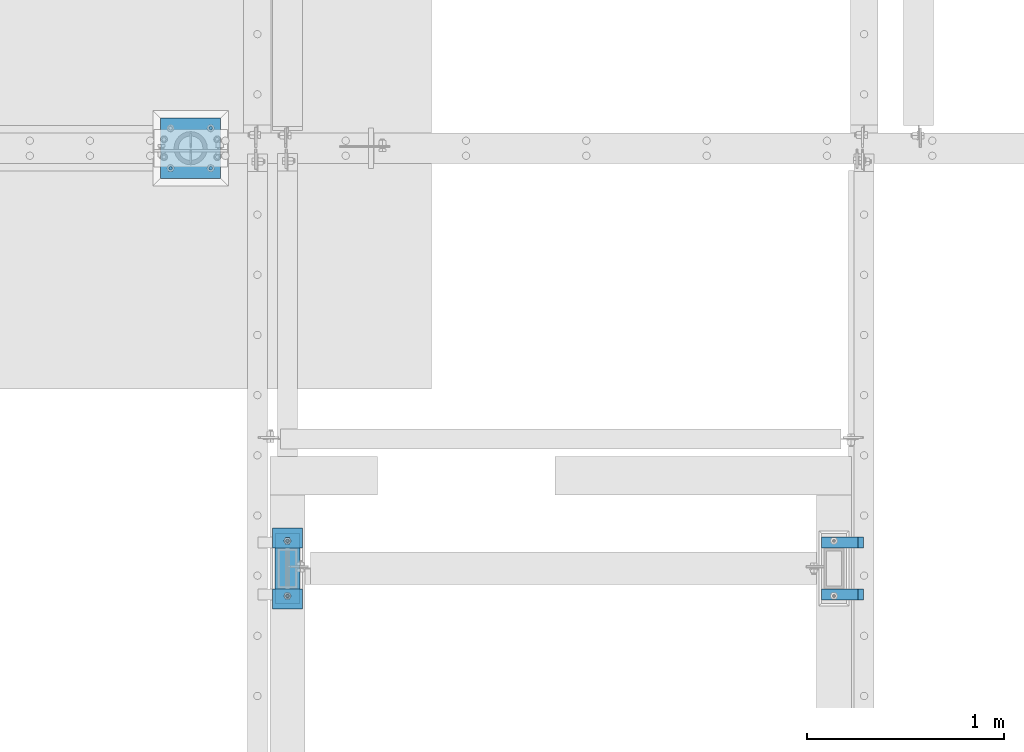
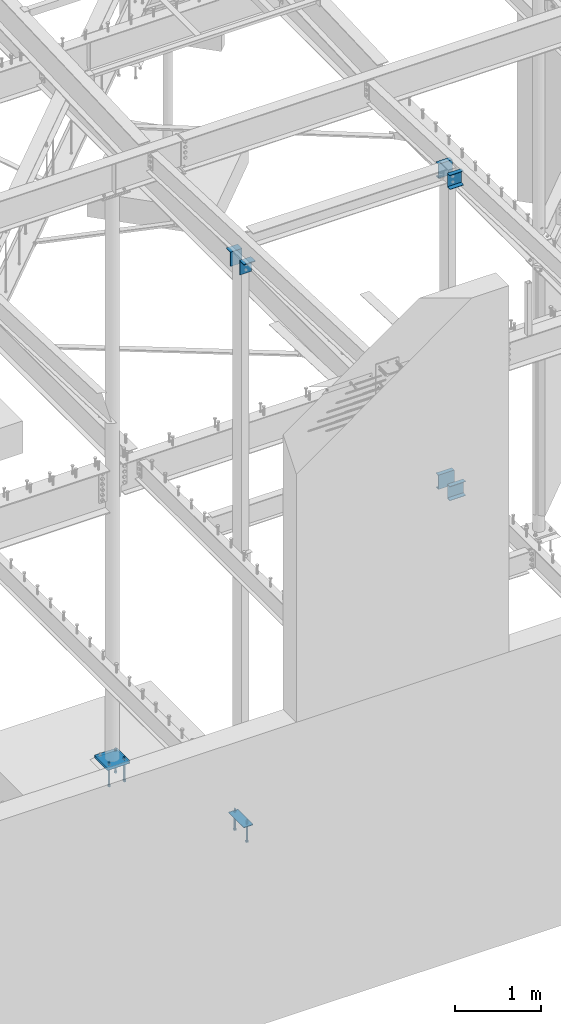
# One storey, part 411 of 975: 15 beams.
"""IFC2X3 building model written with IfcOpenShell, lengths in millimetres."""

import ifcopenshell
import ifcopenshell.guid

model = None  # the IFC model being written
_history = None  # IfcOwnerHistory: only IFC2X3 demands one
_inside = {}  # id of a spatial element -> (the spatial element, [elements in it])
_under = {}  # id of a project, library or spatial element -> (it, [spatial elements below it])
_declared = {}  # id of a project -> (the project, [libraries it declares])
_typed = {}  # id of a type object -> (the type object, [elements of that type])
_made_of = {}  # id of a material, layer set ... -> (it, [elements and type objects made of it])


def new_model(schema):
    """Start an empty IFC model of exactly this schema.

    Asked for "IFC4X3", IfcOpenShell would pick the latest addendum, in which some entities
    have other attributes; the version numbers below select the first issue.
    IFC2X3 requires an IfcOwnerHistory on every rooted entity: one is made here for all.
    """
    global model, _history
    if schema == "IFC4X3":
        model = ifcopenshell.file(schema_version=(4, 3, 0, 0))
    else:
        model = ifcopenshell.file(schema=schema)
    _inside.clear()
    _under.clear()
    _declared.clear()
    _typed.clear()
    _made_of.clear()
    _history = None
    if model.schema == "IFC2X3":
        org = make("IfcOrganization", Name="unknown")
        user = make(
            "IfcPersonAndOrganization",
            ThePerson=make("IfcPerson", FamilyName="unknown"),
            TheOrganization=org,
        )
        app = make(
            "IfcApplication",
            ApplicationDeveloper=org,
            Version="unknown",
            ApplicationFullName="unknown",
            ApplicationIdentifier="unknown",
        )
        _history = make(
            "IfcOwnerHistory",
            OwningUser=user,
            OwningApplication=app,
            ChangeAction="ADDED",
            CreationDate=0,
        )
    return model


def make(cls, **values):
    """One entity of the class cls with the attributes given. An attribute that is None is left unset."""
    return model.create_entity(
        cls, **{name: value for name, value in values.items() if value is not None}
    )


def rooted(cls, **values):
    """An entity with a GlobalId (a new one), such as an element, a storey or a relation."""
    return make(cls, GlobalId=ifcopenshell.guid.new(), OwnerHistory=_history, **values)


def si_unit(unit_type, name, prefix=None):
    """IfcSIUnit, for example si_unit("LENGTHUNIT", "METRE", prefix="MILLI")."""
    return make("IfcSIUnit", UnitType=unit_type, Prefix=prefix, Name=name)


def assignment(units):
    """IfcUnitAssignment: the units of a project."""
    return None if units is None else make("IfcUnitAssignment", Units=units)


def point(xyz):
    """IfcCartesianPoint."""
    return None if xyz is None else make("IfcCartesianPoint", Coordinates=xyz)


def direction(xyz):
    """IfcDirection."""
    return None if xyz is None else make("IfcDirection", DirectionRatios=xyz)


def frame(location, z_axis=None, x_axis=None):
    """IfcAxis2Placement3D, a coordinate frame: its origin and axes. An axis left out is left unset."""
    return make(
        "IfcAxis2Placement3D",
        Location=point(location),
        Axis=direction(z_axis),
        RefDirection=direction(x_axis),
    )


def origin_with_axes():
    """The frame at (0, 0, 0) with the z axis (0, 0, 1) and the x axis (1, 0, 0) written out."""
    return frame((0.0, 0.0, 0.0), z_axis=(0.0, 0.0, 1.0), x_axis=(1.0, 0.0, 0.0))


def place(relative_to, where):
    """IfcLocalPlacement: puts the frame where relative to a parent placement (None: the world)."""
    return make(
        "IfcLocalPlacement", PlacementRelTo=relative_to, RelativePlacement=where
    )


def context(
    kind, dimensions, precision=None, world=None, true_north=None, identifier=None
):
    """IfcGeometricRepresentationContext, for example the 3D "Model" context."""
    return make(
        "IfcGeometricRepresentationContext",
        ContextIdentifier=identifier,
        ContextType=kind,
        CoordinateSpaceDimension=dimensions,
        Precision=precision,
        WorldCoordinateSystem=world,
        TrueNorth=true_north,
    )


def subcontext(parent, identifier, kind, view, scale=None):
    """IfcGeometricRepresentationSubContext, for example "Body" below "Model"."""
    return make(
        "IfcGeometricRepresentationSubContext",
        ContextIdentifier=identifier,
        ContextType=kind,
        ParentContext=parent,
        TargetScale=scale,
        TargetView=view,
    )


def project(units=None, contexts=None):
    """IfcProject with its units and contexts."""
    return rooted(
        "IfcProject",
        Name="project",
        RepresentationContexts=contexts,
        UnitsInContext=assignment(units),
    )


def spatial(cls, under=None, at=None, **own):
    """A site, building, storey or space (cls), placed at a placement, below another one or the project."""
    s = rooted(cls, ObjectPlacement=at, **own)
    if under is not None:
        _under.setdefault(under.id(), (under, []))[1].append(s)
    return s


def faces_of(points, faces, orient=None, outer=None):
    """IfcFace entities. A face is a list of loops; a loop is a list of indices into points, from 0.

    orient and outer hold one flag for each loop. By default every Orientation is true, the
    first loop of a face is its IfcFaceOuterBound and the others are IfcFaceBound.
    """
    made = []
    for i, loops in enumerate(faces):
        bounds = []
        for j, loop in enumerate(loops):
            is_outer = j == 0 if outer is None else outer[i][j]
            bounds.append(
                make(
                    "IfcFaceOuterBound" if is_outer else "IfcFaceBound",
                    Bound=make("IfcPolyLoop", Polygon=[points[k] for k in loop]),
                    Orientation=True if orient is None else orient[i][j],
                )
            )
        made.append(make("IfcFace", Bounds=bounds))
    return made


def faceted_brep(points, faces, orient=None, outer=None, voids=None):
    """IfcFacetedBrep: a solid bounded by flat faces; with voids (closed shells), ...WithVoids."""
    shared = [point(p) for p in points]
    hull = make("IfcClosedShell", CfsFaces=faces_of(shared, faces, orient, outer))
    if voids is None:
        return make("IfcFacetedBrep", Outer=hull)
    return make(
        "IfcFacetedBrepWithVoids",
        Outer=hull,
        Voids=[
            make(cls, CfsFaces=faces_of(shared, fs, o, b)) for cls, fs, o, b in voids
        ],
    )


def shape(context_of_items, identifier, shape_type, items):
    """IfcShapeRepresentation: the items that make up one representation, for example the "Body"."""
    return make(
        "IfcShapeRepresentation",
        ContextOfItems=context_of_items,
        RepresentationIdentifier=identifier,
        RepresentationType=shape_type,
        Items=items,
    )


def material(Name=None, Category=None):
    """IfcMaterial."""
    return make("IfcMaterial", Name=Name, Category=Category)


def made_of(thing, what):
    """Note that an element or type object is made of a material, layer set ...; save() writes the relation."""
    if what is not None:
        _made_of.setdefault(what.id(), (what, []))[1].append(thing)
    return thing


def type_object(cls, material=None, **own):
    """A type object (cls), such as IfcWallType, which elements share."""
    return made_of(rooted(cls, **own), material)


def element(
    cls,
    number,
    at=None,
    inside=None,
    cuts=None,
    type_object=None,
    material=None,
    context=None,
    identifier="Body",
    shape_type=None,
    held_by="IfcProductDefinitionShape",
    body=None,
    shapes=None,
    **own,
):
    """One element of the class cls, such as IfcWall. Its Tag is "e" and its number.

    at: its placement. inside: the storey or other place that contains it. cuts: it is an
    opening in that element (IfcRelVoidsElement). A single representation is given by context,
    identifier, shape_type and body (its items); several are given by shapes. held_by: the class
    of the entity that holds the representations. save() writes the other relations.
    """
    e = rooted(cls, Tag="e%d" % number, ObjectPlacement=at, **own)
    if body is not None:
        shapes = [shape(context, identifier, shape_type, body)]
    if shapes is not None:
        e.Representation = make(held_by, Representations=shapes)
    if inside is not None:
        _inside.setdefault(inside.id(), (inside, []))[1].append(e)
    if cuts is not None:
        rooted(
            "IfcRelVoidsElement", RelatingBuildingElement=cuts, RelatedOpeningElement=e
        )
    if type_object is not None:
        _typed.setdefault(type_object.id(), (type_object, []))[1].append(e)
    return made_of(e, material)


def aggregate(whole, parts):
    """IfcRelAggregates: a whole, such as a stair, and the parts it consists of."""
    return rooted("IfcRelAggregates", RelatingObject=whole, RelatedObjects=parts)


def save(model, path):
    """Write the relations noted so far, then the file.

    IfcRelAggregates (storeys below a building ...), IfcRelContainedInSpatialStructure (elements
    in a storey), IfcRelDefinesByType, IfcRelAssociatesMaterial and IfcRelDeclares: one each for
    every whole, place, type object, material and project.
    """
    for whole, parts in _under.values():
        aggregate(whole, parts)
    for where, things in _inside.values():
        rooted(
            "IfcRelContainedInSpatialStructure",
            RelatedElements=things,
            RelatingStructure=where,
        )
    for kind, things in _typed.values():
        rooted("IfcRelDefinesByType", RelatedObjects=things, RelatingType=kind)
    for what, things in _made_of.values():
        rooted("IfcRelAssociatesMaterial", RelatedObjects=things, RelatingMaterial=what)
    for by, libraries in _declared.values():
        rooted("IfcRelDeclares", RelatingContext=by, RelatedDefinitions=libraries)
    model.write(path)


model = new_model("IFC2X3")

# Units and contexts
model_context = context("Model", 3, precision=1e-05, world=origin_with_axes())
body_context = subcontext(model_context, "Body", "Model", "MODEL_VIEW")
ifc_project = project(units=[si_unit("LENGTHUNIT", "METRE", prefix="MILLI"), si_unit("AREAUNIT", "SQUARE_METRE"), si_unit("VOLUMEUNIT", "CUBIC_METRE"), si_unit("MASSUNIT", "GRAM", prefix="KILO"), si_unit("TIMEUNIT", "SECOND"), si_unit("PLANEANGLEUNIT", "RADIAN"), si_unit("SOLIDANGLEUNIT", "STERADIAN"), si_unit("THERMODYNAMICTEMPERATUREUNIT", "DEGREE_CELSIUS"), si_unit("LUMINOUSINTENSITYUNIT", "LUMEN")], contexts=[model_context])

# Site, building, storey
site_placement = place(None, origin_with_axes())
site = spatial("IfcSite", under=ifc_project, at=site_placement, CompositionType="ELEMENT")
building_placement = place(site_placement, origin_with_axes())
building = spatial("IfcBuilding", under=site, at=building_placement, Name="Undefined", CompositionType="ELEMENT")
storey_placement = place(building_placement, origin_with_axes())
storey = spatial("IfcBuildingStorey", under=building, at=storey_placement, Name="Undefined", CompositionType="ELEMENT", Elevation=0.0)

# Beams
ifc_material_1 = material(Name="STEEL/A36")
beam_type_1 = type_object("IfcBeamType", Name="C8X11.5", PredefinedType="NOTDEFINED")
for number, where, z_axis, x_axis, name in (
    (1, (26428.7000091553, 3822.69997558594, 8175.426563), (0.0, 0.0, -1.0), (1.0, 0.0, 0.0), "BEAM"),
    (2, (26428.7000091553, 3559.17497558594, 8175.426563), (0.0, 0.0, 1.0), (1.0, 0.0, 0.0), "BEAM"),
):
    element("IfcBeam", number, at=place(storey_placement, frame(where, z_axis=z_axis, x_axis=x_axis)), inside=storey, type_object=beam_type_1, material=ifc_material_1, Name=name, ObjectType="C8X11.5", context=body_context, shape_type="Brep", body=[
        faceted_brep([(0.0, 28.5749999999998, -101.6), (0.0, 28.5749999999998, 101.6), (184.943740844727, 28.5749999999998, 101.6), (184.943740844727, 28.5749999999998, -101.6), (0.0, -28.5749999999998, 101.6), (184.943740844727, -28.5749999999998, 101.6), (0.0, -28.5749999999998, 96.8355949999996), (184.943740844727, -28.5749999999998, 96.8355949999996), (0.0, 22.2249999999999, 88.3723149999996), (184.943740844727, 22.2249999999999, 88.3723149999996), (0.0, 22.2249999999999, -88.3723150000005), (184.943740844727, 22.2249999999999, -88.3723150000005), (0.0, -28.5749999999998, -96.8355950000005), (184.943740844727, -28.5749999999998, -96.8355950000005), (0.0, -28.5749999999998, -101.6), (184.943740844727, -28.5749999999998, -101.6)], [[[0, 1, 2, 3]], [[1, 4, 5, 2]], [[4, 6, 7, 5]], [[6, 8, 9, 7]], [[8, 10, 11, 9]], [[10, 12, 13, 11]], [[12, 14, 15, 13]], [[14, 0, 3, 15]], [[5, 7, 9, 11, 13, 15, 3, 2]], [[14, 12, 10, 8, 6, 4, 1, 0]]]),
    ])
for number, where, z_axis, x_axis, name in (
    (3, (26428.7000091553, 3822.69997558594, 3775.075), (0.0, 0.0, -1.0), (1.0, 0.0, 0.0), "BEAM"),
    (4, (26428.7000091553, 3559.17497558594, 3775.075), (0.0, 0.0, 1.0), (1.0, 0.0, 0.0), "BEAM"),
):
    element("IfcBeam", number, at=place(storey_placement, frame(where, z_axis=z_axis, x_axis=x_axis)), inside=storey, type_object=beam_type_1, material=ifc_material_1, Name=name, ObjectType="C8X11.5", context=body_context, shape_type="Brep", body=[
        faceted_brep([(0.0, 28.5749999999998, -101.6), (0.0, 28.5749999999998, 101.6), (212.724990844723, 28.5749999999998, 101.6), (212.724990844723, 28.5749999999998, -101.6), (0.0, -28.5749999999998, 101.6), (212.724990844723, -28.5749999999998, 101.6), (0.0, -28.5749999999998, 96.8355949999996), (212.724990844723, -28.5749999999998, 96.835595), (0.0, 22.2249999999999, 88.3723149999996), (212.724990844723, 22.2249999999999, 88.3723150000001), (0.0, 22.2249999999999, -88.3723150000005), (212.724990844723, 22.2249999999999, -88.3723150000001), (0.0, -28.5749999999998, -96.8355950000005), (212.724990844723, -28.5749999999998, -96.835595), (0.0, -28.5749999999998, -101.6), (212.724990844723, -28.5749999999998, -101.6)], [[[0, 1, 2, 3]], [[1, 4, 5, 2]], [[4, 6, 7, 5]], [[6, 8, 9, 7]], [[8, 10, 11, 9]], [[10, 12, 13, 11]], [[12, 14, 15, 13]], [[14, 0, 3, 15]], [[5, 7, 9, 11, 13, 15, 3, 2]], [[14, 12, 10, 8, 6, 4, 1, 0]]]),
    ])
beam_type_2 = type_object("IfcBeamType", Name="L8X4X7/16", PredefinedType="NOTDEFINED")
for number, where, z_axis, x_axis, name in (
    (5, (23799.7999908447, 3536.95006433962, 7915.69772151655), (0.0, 0.0, -1.0), (-0.999999999999998, 6.90000001668524e-08, 0.0), "ANGLE"),
    (6, (23647.3999908447, 3844.92497558594, 7903.4581268557), (0.0, 0.0, -1.0), (1.0, 0.0, 0.0), "ANGLE"),
):
    element("IfcBeam", number, at=place(storey_placement, frame(where, z_axis=z_axis, x_axis=x_axis)), inside=storey, type_object=beam_type_2, material=ifc_material_1, Name=name, ObjectType="L8X4X7/16", context=body_context, shape_type="Brep", body=[
        faceted_brep([(0.0, 50.8000000000002, -101.6), (0.0, 50.8000000000002, 101.6), (152.400000000001, 50.8000000000002, 101.6), (152.400000000001, 50.8000000000002, -101.6), (0.0, 39.6875, 101.6), (152.400000000001, 39.6875, 101.6), (0.0, 39.6875, -90.4875000000002), (152.400000000001, 39.6875, -90.4875000000002), (0.0, -50.8000000000002, -90.4875000000002), (152.400000000001, -50.8000000000002, -90.4875000000002), (0.0, -50.8000000000002, -101.6), (152.400000000001, -50.8000000000002, -101.6)], [[[0, 1, 2, 3]], [[1, 4, 5, 2]], [[4, 6, 7, 5]], [[6, 8, 9, 7]], [[8, 10, 11, 9]], [[10, 0, 3, 11]], [[5, 7, 9, 11, 3, 2]], [[10, 8, 6, 4, 1, 0]]]),
    ])
ifc_material_2 = material(Name="STEEL/F1554-36")
beam_type_3 = type_object("IfcBeamType", PredefinedType="NOTDEFINED")
beam_1_placement = place(storey_placement, frame((23723.5999908447, 3830.63747558594, -1.36424205265939e-12), z_axis=(0.0, 1.0, 0.0), x_axis=(0.0, 0.0, -1.0)))
element("IfcBeam", 7, at=beam_1_placement, inside=storey, type_object=beam_type_3, material=ifc_material_2, Name="HEADED_ANCHOR_BOLT", context=body_context, shape_type="Brep", body=[
    faceted_brep([(196.84375, -9.12999965559902, 15.8099993757314), (196.84375, -18.2599997700399, -1.0438852768857e-06), (215.893749999999, -18.2599997700399, -1.0438852768857e-06), (215.893749999999, -9.12999965559902, 15.8099993757314), (196.84375, 9.13000057328281, 15.8099993757314), (215.893749999999, 9.13000057328281, 15.8099993757314), (196.84375, 18.2600006877237, -1.0438852768857e-06), (215.893749999999, 18.2600006877237, -1.0438852768857e-06), (196.84375, 9.13000057328281, -15.810001463502), (215.893749999999, 9.13000057328281, -15.810001463502), (196.84375, -9.12999965559902, -15.810001463502), (215.893749999999, -9.12999965559902, -15.810001463502), (196.84375, -4.47767959644079, 9.2979973979138), (196.84375, -8.06850020163256, 6.43441352102286), (196.84375, -10.0612552973498, 2.29641492663589), (196.84375, -10.0612552973498, -2.29641701440644), (196.84375, -8.06850020163256, -6.43441560879344), (196.84375, -4.47767959644079, -9.29799948568439), (196.84375, 4.58841896033846e-07, -10.3200007387095), (196.84375, 4.47768051412459, -9.29799948568436), (196.84375, 8.06850111931635, -6.43441560879342), (196.84375, 10.0612562150336, -2.29641701440644), (196.84375, 10.0612562150336, 2.29641492663589), (196.84375, 8.06850111931635, 6.43441352102289), (196.84375, 4.47768051412459, 9.29799739791383), (196.84375, 4.58841896033846e-07, 10.3199986509389), (215.893749999999, 4.58841896033846e-07, 10.3199986509389), (215.893749999999, -4.47767959644079, 9.2979973979138), (215.893749999999, -8.06850020163256, 6.43441352102286), (215.893749999999, -10.0612552973498, 2.29641492663589), (215.893749999999, -10.0612552973498, -2.29641701440644), (215.893749999999, -8.06850020163256, -6.43441560879344), (215.893749999999, -4.47767959644079, -9.29799948568439), (215.893749999999, 4.58841896033846e-07, -10.3200007387095), (215.893749999999, 4.47768051412459, -9.29799948568436), (215.893749999999, 8.06850111931635, -6.43441560879342), (215.893749999999, 10.0612562150336, -2.29641701440644), (215.893749999999, 10.0612562150336, 2.29641492663589), (215.893749999999, 8.06850111931635, 6.43441352102289), (215.893749999999, 4.47768051412459, 9.29799739791383), (0.0, -6.73519209080223, 6.73519209080186), (0.0, -9.52499999999964, 0.0), (215.900000000001, -9.52499999999964, 0.0), (215.900000000001, -6.73519209080223, 6.73519209080186), (-9.87109982941227e-13, -1.20792265079217e-13, 9.52499961853027), (215.900000000001, 0.0, 9.52500000000001), (0.0, 6.73519209080223, 6.73519209080186), (215.900000000001, 6.73519209080223, 6.73519209080186), (0.0, 9.52499999999964, 0.0), (215.900000000001, 9.52499999999964, 0.0), (0.0, 6.73519209080223, -6.73519209080186), (215.900000000001, 6.73519209080223, -6.73519209080186), (2.95075507493764e-12, -1.20792265079217e-13, -9.52499961853027), (215.900000000001, 0.0, -9.52500000000001), (-88.8979149954284, -6.36396103067818, 6.36396103067909), (-88.8979149954284, 0.0, 9.0), (-88.8979149954284, 6.36396103067818, 6.36396103067909), (-88.8979149954284, 9.0, 0.0), (-88.8979149954284, 6.36396103067818, -6.36396103067909), (-88.8979149954284, 0.0, -9.0), (-88.8979149954284, -6.36396103067818, -6.36396103067909), (-88.8979149954284, -9.0, 0.0), (0.0149743263646087, 6.36396103067818, -6.36396103067909), (0.0149743263646087, 0.0, -9.0), (0.0149743263646087, -6.36396103067818, -6.36396103067909), (0.0149743263987148, -8.9999995411581, -1.00796984270346e-06), (0.0149743263646087, -6.36396103067818, 6.36396103067909), (0.0149743263646087, 0.0, 9.0), (0.0149743263646087, 6.36396103067818, 6.36396103067909), (0.0149743263987148, 9.0000004588419, -1.00796984270346e-06), (0.0, -6.73519209080223, -6.73519209080186), (215.900000000001, -6.73519209080223, -6.73519209080186)], [[[0, 1, 2, 3]], [[4, 0, 3, 5]], [[6, 4, 5, 7]], [[8, 6, 7, 9]], [[10, 8, 9, 11]], [[0, 4, 6, 8, 10, 1], [12, 13, 14, 15, 16, 17, 18, 19, 20, 21, 22, 23, 24, 25]], [[12, 25, 26, 27]], [[13, 12, 27, 28]], [[14, 13, 28, 29]], [[15, 14, 29, 30]], [[16, 15, 30, 31]], [[17, 16, 31, 32]], [[18, 17, 32, 33]], [[19, 18, 33, 34]], [[20, 19, 34, 35]], [[21, 20, 35, 36]], [[22, 21, 36, 37]], [[23, 22, 37, 38]], [[24, 23, 38, 39]], [[25, 24, 39, 26]], [[9, 7, 5, 3, 2, 11], [38, 37, 36, 35, 34, 33, 32, 31, 30, 29, 28, 27, 26, 39]], [[1, 10, 11, 2]], [[40, 41, 42, 43]], [[44, 40, 43, 45]], [[46, 44, 45, 47]], [[48, 46, 47, 49]], [[50, 48, 49, 51]], [[52, 50, 51, 53]], [[54, 55, 56, 57, 58, 59, 60, 61]], [[59, 58, 62, 63]], [[60, 59, 63, 64]], [[61, 60, 64, 65]], [[54, 61, 65, 66]], [[55, 54, 66, 67]], [[56, 55, 67, 68]], [[57, 56, 68, 69]], [[58, 57, 69, 62]], [[40, 44, 46, 48, 50, 52, 70, 41], [68, 67, 66, 65, 64, 63, 62, 69]], [[41, 70, 71, 42]], [[53, 51, 49, 47, 45, 43, 42, 71]], [[70, 52, 53, 71]]]),
])
beam_2_placement = place(storey_placement, frame((23723.5999908447, 3551.23747558594, -1.36424205265939e-12), z_axis=(0.0, 1.0, 0.0), x_axis=(0.0, 0.0, -1.0)))
element("IfcBeam", 8, at=beam_2_placement, inside=storey, type_object=beam_type_3, material=ifc_material_2, Name="HEADED_ANCHOR_BOLT", context=body_context, shape_type="Brep", body=[
    faceted_brep([(196.84375, -9.12999965559902, 15.8099993757314), (196.84375, -18.2599997700399, -1.0438852768857e-06), (215.893749999999, -18.2599997700399, -1.0438852768857e-06), (215.893749999999, -9.12999965559902, 15.8099993757314), (196.84375, 9.13000057328281, 15.8099993757314), (215.893749999999, 9.13000057328281, 15.8099993757314), (196.84375, 18.2600006877237, -1.0438852768857e-06), (215.893749999999, 18.2600006877237, -1.0438852768857e-06), (196.84375, 9.13000057328281, -15.810001463502), (215.893749999999, 9.13000057328281, -15.810001463502), (196.84375, -9.12999965559902, -15.810001463502), (215.893749999999, -9.12999965559902, -15.810001463502), (196.84375, -4.47767959644079, 9.2979973979138), (196.84375, -8.06850020163256, 6.43441352102286), (196.84375, -10.0612552973498, 2.29641492663589), (196.84375, -10.0612552973498, -2.29641701440644), (196.84375, -8.06850020163256, -6.43441560879344), (196.84375, -4.47767959644079, -9.29799948568439), (196.84375, 4.58841896033846e-07, -10.3200007387095), (196.84375, 4.47768051412459, -9.29799948568436), (196.84375, 8.06850111931635, -6.43441560879342), (196.84375, 10.0612562150336, -2.29641701440644), (196.84375, 10.0612562150336, 2.29641492663589), (196.84375, 8.06850111931635, 6.43441352102289), (196.84375, 4.47768051412459, 9.29799739791383), (196.84375, 4.58841896033846e-07, 10.3199986509389), (215.893749999999, 4.58841896033846e-07, 10.3199986509389), (215.893749999999, -4.47767959644079, 9.2979973979138), (215.893749999999, -8.06850020163256, 6.43441352102286), (215.893749999999, -10.0612552973498, 2.29641492663589), (215.893749999999, -10.0612552973498, -2.29641701440644), (215.893749999999, -8.06850020163256, -6.43441560879344), (215.893749999999, -4.47767959644079, -9.29799948568439), (215.893749999999, 4.58841896033846e-07, -10.3200007387095), (215.893749999999, 4.47768051412459, -9.29799948568436), (215.893749999999, 8.06850111931635, -6.43441560879342), (215.893749999999, 10.0612562150336, -2.29641701440644), (215.893749999999, 10.0612562150336, 2.29641492663589), (215.893749999999, 8.06850111931635, 6.43441352102289), (215.893749999999, 4.47768051412459, 9.29799739791383), (0.0, -6.73519209080223, 6.73519209080186), (0.0, -9.52499999999964, 0.0), (215.900000000001, -9.52499999999964, 0.0), (215.900000000001, -6.73519209080223, 6.73519209080186), (-9.87109982941227e-13, -1.20792265079217e-13, 9.52499961853027), (215.900000000001, 0.0, 9.52500000000001), (0.0, 6.73519209080223, 6.73519209080186), (215.900000000001, 6.73519209080223, 6.73519209080186), (0.0, 9.52499999999964, 0.0), (215.900000000001, 9.52499999999964, 0.0), (0.0, 6.73519209080223, -6.73519209080186), (215.900000000001, 6.73519209080223, -6.73519209080186), (2.95075507493764e-12, -1.20792265079217e-13, -9.52499961853027), (215.900000000001, 0.0, -9.52500000000001), (-88.8979149954284, -6.36396103067818, 6.36396103067909), (-88.8979149954284, 0.0, 9.0), (-88.8979149954284, 6.36396103067818, 6.36396103067909), (-88.8979149954284, 9.0, 0.0), (-88.8979149954284, 6.36396103067818, -6.36396103067909), (-88.8979149954284, 0.0, -9.0), (-88.8979149954284, -6.36396103067818, -6.36396103067909), (-88.8979149954284, -9.0, 0.0), (0.0149743263646087, 6.36396103067818, -6.36396103067909), (0.0149743263646087, 0.0, -9.0), (0.0149743263646087, -6.36396103067818, -6.36396103067909), (0.0149743263987148, -8.9999995411581, -1.00796984270346e-06), (0.0149743263646087, -6.36396103067818, 6.36396103067909), (0.0149743263646087, 0.0, 9.0), (0.0149743263646087, 6.36396103067818, 6.36396103067909), (0.0149743263987148, 9.0000004588419, -1.00796984270346e-06), (0.0, -6.73519209080223, -6.73519209080186), (215.900000000001, -6.73519209080223, -6.73519209080186)], [[[0, 1, 2, 3]], [[4, 0, 3, 5]], [[6, 4, 5, 7]], [[8, 6, 7, 9]], [[10, 8, 9, 11]], [[0, 4, 6, 8, 10, 1], [12, 13, 14, 15, 16, 17, 18, 19, 20, 21, 22, 23, 24, 25]], [[12, 25, 26, 27]], [[13, 12, 27, 28]], [[14, 13, 28, 29]], [[15, 14, 29, 30]], [[16, 15, 30, 31]], [[17, 16, 31, 32]], [[18, 17, 32, 33]], [[19, 18, 33, 34]], [[20, 19, 34, 35]], [[21, 20, 35, 36]], [[22, 21, 36, 37]], [[23, 22, 37, 38]], [[24, 23, 38, 39]], [[25, 24, 39, 26]], [[9, 7, 5, 3, 2, 11], [38, 37, 36, 35, 34, 33, 32, 31, 30, 29, 28, 27, 26, 39]], [[1, 10, 11, 2]], [[40, 41, 42, 43]], [[44, 40, 43, 45]], [[46, 44, 45, 47]], [[48, 46, 47, 49]], [[50, 48, 49, 51]], [[52, 50, 51, 53]], [[54, 55, 56, 57, 58, 59, 60, 61]], [[59, 58, 62, 63]], [[60, 59, 63, 64]], [[61, 60, 64, 65]], [[54, 61, 65, 66]], [[55, 54, 66, 67]], [[56, 55, 67, 68]], [[57, 56, 68, 69]], [[58, 57, 69, 62]], [[40, 44, 46, 48, 50, 52, 70, 41], [68, 67, 66, 65, 64, 63, 62, 69]], [[41, 70, 71, 42]], [[53, 51, 49, 47, 45, 43, 42, 71]], [[70, 52, 53, 71]]]),
])
beam_3_placement = place(storey_placement, frame((23131.4625015259, 5718.17500305176, -304.799999999999), z_axis=(0.0, -1.0, 0.0), x_axis=(0.0, 0.0, -1.0)))
element("IfcBeam", 9, at=beam_3_placement, inside=storey, type_object=beam_type_3, material=ifc_material_2, Name="HEADED_ANCHOR_BOLT", context=body_context, shape_type="Brep", body=[
    faceted_brep([(209.543749999999, -9.13000011446275, 15.8100004196049), (209.543749999999, -18.2600002288382, 4.72937244921923e-11), (228.593749999998, -18.2600002288382, 4.72937244921923e-11), (228.593749999998, -9.13000011446275, 15.8100004196049), (209.543749999999, 9.13000011438271, 15.8100004195576), (228.593749999998, 9.13000011438271, 15.8100004195576), (209.543749999999, 18.2600002288382, -4.72937244921923e-11), (228.593749999998, 18.2600002288382, -4.72937244921923e-11), (209.543749999999, 9.13000011446275, -15.8100004196049), (228.593749999998, 9.13000011446275, -15.8100004196049), (209.543749999999, -9.13000011438271, -15.8100004195576), (228.593749999998, -9.13000011438271, -15.8100004195576), (209.543749999999, -4.4776800552936, 9.29799844178979), (209.543749999999, -8.068500660469, 6.43441456491473), (209.543749999999, -10.0612557561763, 2.2964159705416), (209.543749999999, -10.0612557561617, -2.29641597048976), (209.543749999999, -8.0685006604399, -6.4344145648729), (209.543749999999, -4.47768005524995, -9.29799844176705), (209.543749999999, 2.91038304567337e-11, -10.3199996948015), (209.543749999999, 4.4776800552936, -9.29799844178979), (209.543749999999, 8.068500660469, -6.43441456491473), (209.543749999999, 10.0612557561763, -2.2964159705416), (209.543749999999, 10.0612557561617, 2.29641597048976), (209.543749999999, 8.0685006604399, 6.4344145648729), (209.543749999999, 4.47768005524995, 9.29799844176705), (209.543749999999, -2.91038304567337e-11, 10.3199996948015), (228.593749999998, -2.91038304567337e-11, 10.3199996948015), (228.593749999998, -4.4776800552936, 9.29799844178979), (228.593749999998, -8.068500660469, 6.43441456491473), (228.593749999998, -10.0612557561763, 2.2964159705416), (228.593749999998, -10.0612557561617, -2.29641597048976), (228.593749999998, -8.0685006604399, -6.4344145648729), (228.593749999998, -4.47768005524995, -9.29799844176705), (228.593749999998, 2.91038304567337e-11, -10.3199996948015), (228.593749999998, 4.4776800552936, -9.29799844178979), (228.593749999998, 8.068500660469, -6.43441456491473), (228.593749999998, 10.0612557561763, -2.2964159705416), (228.593749999998, 10.0612557561617, 2.29641597048976), (228.593749999998, 8.0685006604399, 6.4344145648729), (228.593749999998, 4.47768005524995, 9.29799844176705), (0.0, -6.73519209080223, 6.73519209080186), (0.0, -9.52499999999964, 0.0), (228.6, -9.52500000000146, 0.0), (228.6, -6.73519209080405, 6.73519209080223), (-9.87109982941227e-13, -1.20792265079217e-13, 9.52499961853027), (228.6, 0.0, 9.52499999999964), (0.0, 6.73519209080223, 6.73519209080186), (228.6, 6.73519209080405, 6.73519209080223), (0.0, 9.52499999999964, 0.0), (228.6, 9.52500000000146, 0.0), (0.0, 6.73519209080223, -6.73519209080186), (228.6, 6.73519209080405, -6.73519209080223), (2.95075507493764e-12, -1.20792265079217e-13, -9.52499961853027), (228.6, 0.0, -9.52499999999964), (-114.299999999999, -6.36396103067818, 6.36396103067909), (-114.299999999999, 0.0, 9.0), (-114.299999999999, 6.36396103067818, 6.36396103067909), (-114.299999999999, 9.0, 0.0), (-114.299999999999, 6.36396103067818, -6.36396103067909), (-114.299999999999, 0.0, -9.0), (-114.299999999999, -6.36396103067818, -6.36396103067909), (-114.299999999999, -9.0, 0.0), (0.0, 6.36396103067818, -6.36396103067909), (0.0, 0.0, -9.0), (0.0, -6.36396103067818, -6.36396103067909), (0.0, -9.0, 0.0), (0.0, -6.36396103067818, 6.36396103067909), (0.0, 0.0, 9.0), (0.0, 6.36396103067818, 6.36396103067909), (0.0, 9.0, 0.0), (0.0, -6.73519209080223, -6.73519209080186), (228.6, -6.73519209080405, -6.73519209080223)], [[[0, 1, 2, 3]], [[4, 0, 3, 5]], [[6, 4, 5, 7]], [[8, 6, 7, 9]], [[10, 8, 9, 11]], [[0, 4, 6, 8, 10, 1], [12, 13, 14, 15, 16, 17, 18, 19, 20, 21, 22, 23, 24, 25]], [[12, 25, 26, 27]], [[13, 12, 27, 28]], [[14, 13, 28, 29]], [[15, 14, 29, 30]], [[16, 15, 30, 31]], [[17, 16, 31, 32]], [[18, 17, 32, 33]], [[19, 18, 33, 34]], [[20, 19, 34, 35]], [[21, 20, 35, 36]], [[22, 21, 36, 37]], [[23, 22, 37, 38]], [[24, 23, 38, 39]], [[25, 24, 39, 26]], [[9, 7, 5, 3, 2, 11], [38, 37, 36, 35, 34, 33, 32, 31, 30, 29, 28, 27, 26, 39]], [[1, 10, 11, 2]], [[40, 41, 42, 43]], [[44, 40, 43, 45]], [[46, 44, 45, 47]], [[48, 46, 47, 49]], [[50, 48, 49, 51]], [[52, 50, 51, 53]], [[54, 55, 56, 57, 58, 59, 60, 61]], [[59, 58, 62, 63]], [[60, 59, 63, 64]], [[61, 60, 64, 65]], [[54, 61, 65, 66]], [[55, 54, 66, 67]], [[56, 55, 67, 68]], [[57, 56, 68, 69]], [[58, 57, 69, 62]], [[40, 44, 46, 48, 50, 52, 70, 41], [68, 67, 66, 65, 64, 63, 62, 69]], [[41, 70, 71, 42]], [[53, 51, 49, 47, 45, 43, 42, 71]], [[70, 52, 53, 71]]]),
])
beam_4_placement = place(storey_placement, frame((23334.6624984741, 5921.375, -304.799999999999), z_axis=(0.0, -1.0, 0.0), x_axis=(0.0, 0.0, -1.0)))
element("IfcBeam", 10, at=beam_4_placement, inside=storey, type_object=beam_type_3, material=ifc_material_2, Name="HEADED_ANCHOR_BOLT", context=body_context, shape_type="Brep", body=[
    faceted_brep([(209.543749999999, 9.13000011446275, -15.8100004196049), (209.543749999999, 18.2600002288382, -4.72937244921923e-11), (228.593749999998, 18.2600002288382, -4.72937244921923e-11), (228.593749999998, 9.13000011446275, -15.8100004196049), (209.543749999999, -9.13000011438271, -15.8100004195576), (228.593749999998, -9.13000011438271, -15.8100004195576), (209.543749999999, -18.2600002288382, 4.72937244921923e-11), (228.593749999998, -18.2600002288382, 4.72937244921923e-11), (209.543749999999, -9.13000011446275, 15.8100004196049), (228.593749999998, -9.13000011446275, 15.8100004196049), (209.543749999999, 9.13000011438271, 15.8100004195576), (228.593749999998, 9.13000011438271, 15.8100004195576), (209.543749999999, -4.4776800552936, 9.29799844178979), (209.543749999999, -8.068500660469, 6.43441456491473), (209.543749999999, -10.0612557561763, 2.2964159705416), (209.543749999999, -10.0612557561617, -2.29641597048976), (209.543749999999, -8.0685006604399, -6.4344145648729), (209.543749999999, -4.47768005524995, -9.29799844176705), (209.543749999999, 2.91038304567337e-11, -10.3199996948015), (209.543749999999, 4.4776800552936, -9.29799844178979), (209.543749999999, 8.068500660469, -6.43441456491473), (209.543749999999, 10.0612557561763, -2.2964159705416), (209.543749999999, 10.0612557561617, 2.29641597048976), (209.543749999999, 8.0685006604399, 6.4344145648729), (209.543749999999, 4.47768005524995, 9.29799844176705), (209.543749999999, -2.91038304567337e-11, 10.3199996948015), (228.593749999998, 2.91038304567337e-11, -10.3199996948015), (228.593749999998, 4.4776800552936, -9.29799844178979), (228.593749999998, 8.068500660469, -6.43441456491473), (228.593749999998, 10.0612557561763, -2.2964159705416), (228.593749999998, 10.0612557561617, 2.29641597048976), (228.593749999998, 8.0685006604399, 6.4344145648729), (228.593749999998, 4.47768005524995, 9.29799844176705), (228.593749999998, -2.91038304567337e-11, 10.3199996948015), (228.593749999998, -4.4776800552936, 9.29799844178979), (228.593749999998, -8.068500660469, 6.43441456491473), (228.593749999998, -10.0612557561763, 2.2964159705416), (228.593749999998, -10.0612557561617, -2.29641597048976), (228.593749999998, -8.0685006604399, -6.4344145648729), (228.593749999998, -4.47768005524995, -9.29799844176705), (0.0, -6.73519209080223, 6.73519209080186), (0.0, -9.52499999999964, 0.0), (228.6, -9.52500000000146, 0.0), (228.6, -6.73519209080405, 6.73519209080223), (-9.87109982941227e-13, -1.20792265079217e-13, 9.52499961853027), (228.6, 0.0, 9.52499999999964), (0.0, 6.73519209080223, 6.73519209080186), (228.6, 6.73519209080405, 6.73519209080223), (0.0, 9.52499999999964, 0.0), (228.6, 9.52500000000146, 0.0), (0.0, 6.73519209080223, -6.73519209080186), (228.6, 6.73519209080405, -6.73519209080223), (2.95075507493764e-12, -1.20792265079217e-13, -9.52499961853027), (228.6, 0.0, -9.52499999999964), (-114.299999999999, -6.36396103067818, 6.36396103067909), (-114.299999999999, 0.0, 9.0), (-114.299999999999, 6.36396103067818, 6.36396103067909), (-114.299999999999, 9.0, 0.0), (-114.299999999999, 6.36396103067818, -6.36396103067909), (-114.299999999999, 0.0, -9.0), (-114.299999999999, -6.36396103067818, -6.36396103067909), (-114.299999999999, -9.0, 0.0), (0.0, 6.36396103067818, -6.36396103067909), (0.0, 0.0, -9.0), (0.0, -6.36396103067818, -6.36396103067909), (0.0, -9.0, 0.0), (0.0, -6.36396103067818, 6.36396103067909), (0.0, 0.0, 9.0), (0.0, 6.36396103067818, 6.36396103067909), (0.0, 9.0, 0.0), (0.0, -6.73519209080223, -6.73519209080186), (228.6, -6.73519209080405, -6.73519209080223)], [[[0, 1, 2, 3]], [[4, 0, 3, 5]], [[6, 4, 5, 7]], [[8, 6, 7, 9]], [[10, 8, 9, 11]], [[8, 10, 1, 0, 4, 6], [12, 13, 14, 15, 16, 17, 18, 19, 20, 21, 22, 23, 24, 25]], [[19, 18, 26, 27]], [[20, 19, 27, 28]], [[21, 20, 28, 29]], [[22, 21, 29, 30]], [[23, 22, 30, 31]], [[24, 23, 31, 32]], [[25, 24, 32, 33]], [[12, 25, 33, 34]], [[13, 12, 34, 35]], [[14, 13, 35, 36]], [[15, 14, 36, 37]], [[16, 15, 37, 38]], [[17, 16, 38, 39]], [[18, 17, 39, 26]], [[3, 2, 11, 9, 7, 5], [31, 30, 29, 28, 27, 26, 39, 38, 37, 36, 35, 34, 33, 32]], [[1, 10, 11, 2]], [[40, 41, 42, 43]], [[44, 40, 43, 45]], [[46, 44, 45, 47]], [[48, 46, 47, 49]], [[50, 48, 49, 51]], [[52, 50, 51, 53]], [[54, 55, 56, 57, 58, 59, 60, 61]], [[59, 58, 62, 63]], [[60, 59, 63, 64]], [[61, 60, 64, 65]], [[54, 61, 65, 66]], [[55, 54, 66, 67]], [[56, 55, 67, 68]], [[57, 56, 68, 69]], [[58, 57, 69, 62]], [[40, 44, 46, 48, 50, 52, 70, 41], [68, 67, 66, 65, 64, 63, 62, 69]], [[41, 70, 71, 42]], [[53, 51, 49, 47, 45, 43, 42, 71]], [[70, 52, 53, 71]]]),
])
beam_5_placement = place(storey_placement, frame((23334.6624984741, 5718.17500305176, -304.799999999999), z_axis=(0.0, -1.0, 0.0), x_axis=(0.0, 0.0, -1.0)))
element("IfcBeam", 11, at=beam_5_placement, inside=storey, type_object=beam_type_3, material=ifc_material_2, Name="HEADED_ANCHOR_BOLT", context=body_context, shape_type="Brep", body=[
    faceted_brep([(209.543749999999, 9.13000011446275, -15.8100004196049), (209.543749999999, 18.2600002288382, -4.72937244921923e-11), (228.593749999998, 18.2600002288382, -4.72937244921923e-11), (228.593749999998, 9.13000011446275, -15.8100004196049), (209.543749999999, -9.13000011438271, -15.8100004195576), (228.593749999998, -9.13000011438271, -15.8100004195576), (209.543749999999, -18.2600002288382, 4.72937244921923e-11), (228.593749999998, -18.2600002288382, 4.72937244921923e-11), (209.543749999999, -9.13000011446275, 15.8100004196049), (228.593749999998, -9.13000011446275, 15.8100004196049), (209.543749999999, 9.13000011438271, 15.8100004195576), (228.593749999998, 9.13000011438271, 15.8100004195576), (209.543749999999, -4.4776800552936, 9.29799844178979), (209.543749999999, -8.068500660469, 6.43441456491473), (209.543749999999, -10.0612557561763, 2.2964159705416), (209.543749999999, -10.0612557561617, -2.29641597048976), (209.543749999999, -8.0685006604399, -6.4344145648729), (209.543749999999, -4.47768005524995, -9.29799844176705), (209.543749999999, 2.91038304567337e-11, -10.3199996948015), (209.543749999999, 4.4776800552936, -9.29799844178979), (209.543749999999, 8.068500660469, -6.43441456491473), (209.543749999999, 10.0612557561763, -2.2964159705416), (209.543749999999, 10.0612557561617, 2.29641597048976), (209.543749999999, 8.0685006604399, 6.4344145648729), (209.543749999999, 4.47768005524995, 9.29799844176705), (209.543749999999, -2.91038304567337e-11, 10.3199996948015), (228.593749999998, 2.91038304567337e-11, -10.3199996948015), (228.593749999998, 4.4776800552936, -9.29799844178979), (228.593749999998, 8.068500660469, -6.43441456491473), (228.593749999998, 10.0612557561763, -2.2964159705416), (228.593749999998, 10.0612557561617, 2.29641597048976), (228.593749999998, 8.0685006604399, 6.4344145648729), (228.593749999998, 4.47768005524995, 9.29799844176705), (228.593749999998, -2.91038304567337e-11, 10.3199996948015), (228.593749999998, -4.4776800552936, 9.29799844178979), (228.593749999998, -8.068500660469, 6.43441456491473), (228.593749999998, -10.0612557561763, 2.2964159705416), (228.593749999998, -10.0612557561617, -2.29641597048976), (228.593749999998, -8.0685006604399, -6.4344145648729), (228.593749999998, -4.47768005524995, -9.29799844176705), (0.0, -6.73519209080223, 6.73519209080186), (0.0, -9.52499999999964, 0.0), (228.6, -9.52500000000146, 0.0), (228.6, -6.73519209080405, 6.73519209080223), (-9.87109982941227e-13, -1.20792265079217e-13, 9.52499961853027), (228.6, 0.0, 9.52499999999964), (0.0, 6.73519209080223, 6.73519209080186), (228.6, 6.73519209080405, 6.73519209080223), (0.0, 9.52499999999964, 0.0), (228.6, 9.52500000000146, 0.0), (0.0, 6.73519209080223, -6.73519209080186), (228.6, 6.73519209080405, -6.73519209080223), (2.95075507493764e-12, -1.20792265079217e-13, -9.52499961853027), (228.6, 0.0, -9.52499999999964), (-114.299999999999, -6.36396103067818, 6.36396103067909), (-114.299999999999, 0.0, 9.0), (-114.299999999999, 6.36396103067818, 6.36396103067909), (-114.299999999999, 9.0, 0.0), (-114.299999999999, 6.36396103067818, -6.36396103067909), (-114.299999999999, 0.0, -9.0), (-114.299999999999, -6.36396103067818, -6.36396103067909), (-114.299999999999, -9.0, 0.0), (0.0, 6.36396103067818, -6.36396103067909), (0.0, 0.0, -9.0), (0.0, -6.36396103067818, -6.36396103067909), (0.0, -9.0, 0.0), (0.0, -6.36396103067818, 6.36396103067909), (0.0, 0.0, 9.0), (0.0, 6.36396103067818, 6.36396103067909), (0.0, 9.0, 0.0), (0.0, -6.73519209080223, -6.73519209080186), (228.6, -6.73519209080405, -6.73519209080223)], [[[0, 1, 2, 3]], [[4, 0, 3, 5]], [[6, 4, 5, 7]], [[8, 6, 7, 9]], [[10, 8, 9, 11]], [[8, 10, 1, 0, 4, 6], [12, 13, 14, 15, 16, 17, 18, 19, 20, 21, 22, 23, 24, 25]], [[19, 18, 26, 27]], [[20, 19, 27, 28]], [[21, 20, 28, 29]], [[22, 21, 29, 30]], [[23, 22, 30, 31]], [[24, 23, 31, 32]], [[25, 24, 32, 33]], [[12, 25, 33, 34]], [[13, 12, 34, 35]], [[14, 13, 35, 36]], [[15, 14, 36, 37]], [[16, 15, 37, 38]], [[17, 16, 38, 39]], [[18, 17, 39, 26]], [[3, 2, 11, 9, 7, 5], [31, 30, 29, 28, 27, 26, 39, 38, 37, 36, 35, 34, 33, 32]], [[1, 10, 11, 2]], [[40, 41, 42, 43]], [[44, 40, 43, 45]], [[46, 44, 45, 47]], [[48, 46, 47, 49]], [[50, 48, 49, 51]], [[52, 50, 51, 53]], [[54, 55, 56, 57, 58, 59, 60, 61]], [[59, 58, 62, 63]], [[60, 59, 63, 64]], [[61, 60, 64, 65]], [[54, 61, 65, 66]], [[55, 54, 66, 67]], [[56, 55, 67, 68]], [[57, 56, 68, 69]], [[58, 57, 69, 62]], [[40, 44, 46, 48, 50, 52, 70, 41], [68, 67, 66, 65, 64, 63, 62, 69]], [[41, 70, 71, 42]], [[53, 51, 49, 47, 45, 43, 42, 71]], [[70, 52, 53, 71]]]),
])
beam_type_4 = type_object("IfcBeamType", PredefinedType="NOTDEFINED")
beam_6_placement = place(storey_placement, frame((23723.5999908447, 3868.73747558594, 31.7500000000026), z_axis=(1.0, 0.0, 0.0), x_axis=(0.0, -1.0, 0.0)))
element("IfcBeam", 12, at=beam_6_placement, inside=storey, type_object=beam_type_4, material=ifc_material_1, Name="PLATE", context=body_context, shape_type="Brep", body=[
    faceted_brep([(0.0, 6.35, -63.5), (0.0, 6.35, 63.5), (355.6, 6.35, 63.5), (355.6, 6.35, -63.5), (0.0, -6.35, 63.5), (355.6, -6.35, 63.5), (0.0, -6.35, -63.5), (355.6, -6.35, -63.5)], [[[0, 1, 2, 3]], [[1, 4, 5, 2]], [[4, 6, 7, 5]], [[6, 0, 3, 7]], [[5, 7, 3, 2]], [[6, 4, 1, 0]]]),
])
beam_type_5 = type_object("IfcBeamType", PredefinedType="NOTDEFINED")
beam_7_placement = place(storey_placement, frame((23723.5999908447, 3868.73747558594, 26.9875000000037), z_axis=(1.0, 0.0, 0.0), x_axis=(0.0, -1.0, 0.0)))
element("IfcBeam", 13, at=beam_7_placement, inside=storey, type_object=beam_type_5, material=ifc_material_1, Name="TEMPLATE", context=body_context, shape_type="Brep", body=[
    faceted_brep([(0.0, 1.5875, -63.5), (0.0, 1.5875, 63.5), (355.6, 1.5875, 63.5), (355.6, 1.5875, -63.5), (0.0, -1.5875, 63.5), (355.6, -1.5875, 63.5), (0.0, -1.5875, -63.5), (355.6, -1.5875, -63.5)], [[[0, 1, 2, 3]], [[1, 4, 5, 2]], [[4, 6, 7, 5]], [[6, 0, 3, 7]], [[5, 7, 3, 2]], [[6, 4, 1, 0]]]),
])
beam_type_6 = type_object("IfcBeamType", PredefinedType="NOTDEFINED")
beam_8_placement = place(storey_placement, frame((23233.0625, 5667.375, -265.112500000001), z_axis=(-0.999999999999998, 6.90000001668524e-08, 0.0), x_axis=(0.0, 1.0, 0.0)))
element("IfcBeam", 14, at=beam_8_placement, inside=storey, type_object=beam_type_6, material=ifc_material_1, Name="TEMPLATE", context=body_context, shape_type="Brep", body=[
    faceted_brep([(0.0, 1.58750000000009, -152.4), (0.0, 1.58750000000009, 152.4), (304.799999999153, 1.58750000000001, 152.400000000001), (304.799999999153, 1.58750000000001, -152.400000000001), (0.0, -1.58750000000009, 152.4), (304.799999999153, -1.58750000000001, 152.400000000001), (0.0, -1.58750000000009, -152.4), (304.799999999153, -1.58750000000001, -152.400000000001)], [[[0, 1, 2, 3]], [[1, 4, 5, 2]], [[4, 6, 7, 5]], [[6, 0, 3, 7]], [[5, 7, 3, 2]], [[6, 4, 1, 0]]]),
])
beam_type_7 = type_object("IfcBeamType", PredefinedType="NOTDEFINED")
beam_9_placement = place(storey_placement, frame((23233.0625, 5667.375, -249.2375), z_axis=(-0.999999999999998, 6.90000001668524e-08, 0.0), x_axis=(0.0, 1.0, 0.0)))
element("IfcBeam", 15, at=beam_9_placement, inside=storey, type_object=beam_type_7, material=ifc_material_1, Name="TEMPLATE", context=body_context, shape_type="Brep", body=[
    faceted_brep([(0.0, 17.4625, -152.400000000001), (0.0, 17.4625, 152.400000000001), (304.800000000003, 17.4625, 152.400000000001), (304.800000000003, 17.4625, -152.400000000001), (0.0, -17.4625, 152.400000000001), (304.800000000003, -17.4625, 152.400000000001), (0.0, -17.4625, -152.400000000001), (304.800000000003, -17.4625, -152.400000000001)], [[[0, 1, 2, 3]], [[1, 4, 5, 2]], [[4, 6, 7, 5]], [[6, 0, 3, 7]], [[5, 7, 3, 2]], [[6, 4, 1, 0]]]),
])

save(model, "model.ifc")
